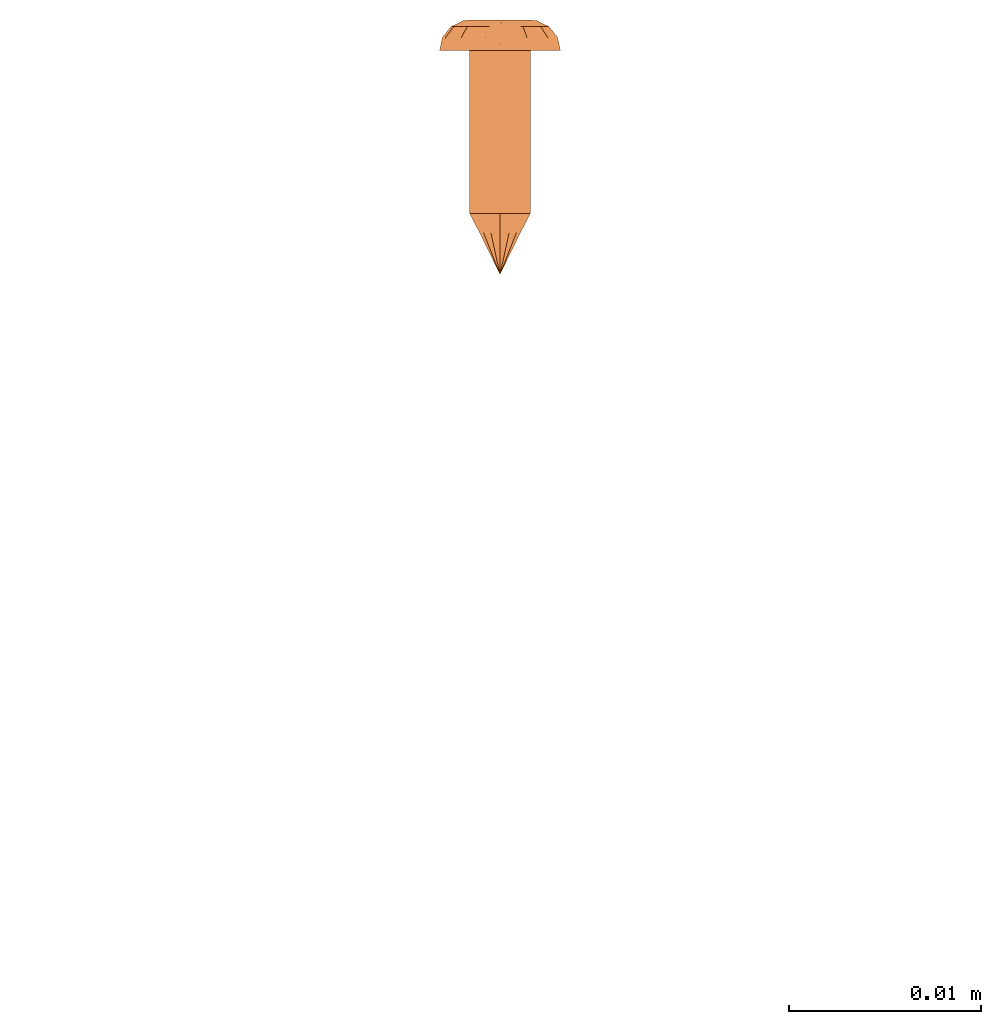
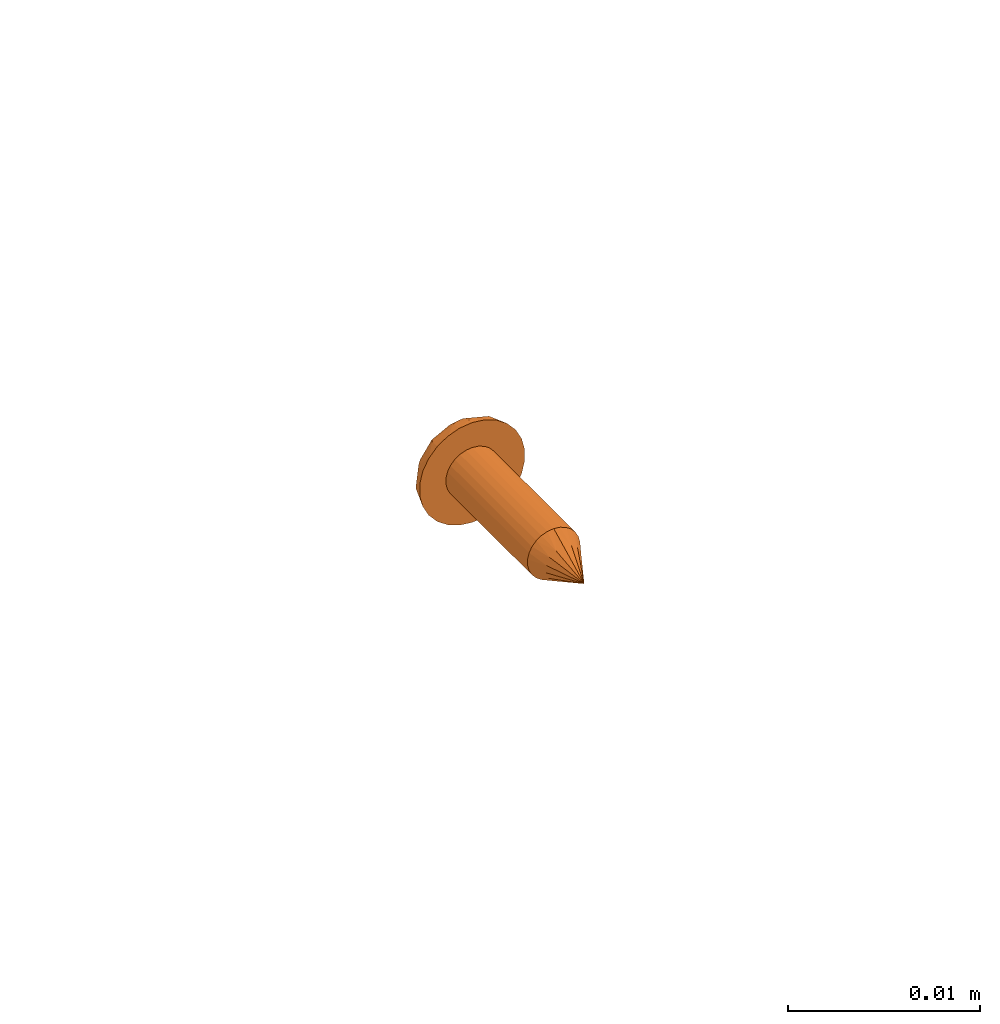
# One storey, part 41 of 44: 1 proxy.
"""IFC4 building model written with IfcOpenShell, lengths in feet."""

from ifc_helpers import new_model, entity, si_unit, converted_unit, derived_unit, direction, frame, origin, place, context, subcontext, project, spatial, source, transform, mapped, material, type_object, type_shapes, element, save


model = new_model("IFC4")

# Units and contexts
model_context = context("Model", 3, precision=0.0001, world=origin(), true_north=direction((6.12303176911189e-17, 1.0)))
body_context = subcontext(model_context, "Body", "Model", "MODEL_VIEW")
ifc_project = project(units=[converted_unit("LENGTHUNIT", "FOOT", entity("IfcRatioMeasure", 0.3048), si_unit("LENGTHUNIT", "METRE"), dimensions=[1, 0, 0, 0, 0, 0, 0]), converted_unit("AREAUNIT", "SQUARE FOOT", entity("IfcRatioMeasure", 0.09290304), si_unit("AREAUNIT", "SQUARE_METRE"), dimensions=[2, 0, 0, 0, 0, 0, 0]), converted_unit("VOLUMEUNIT", "CUBIC FOOT", entity("IfcRatioMeasure", 0.028316846592), si_unit("VOLUMEUNIT", "CUBIC_METRE"), dimensions=[3, 0, 0, 0, 0, 0, 0]), converted_unit("PLANEANGLEUNIT", "DEGREE", entity("IfcRatioMeasure", 0.0174532925199433), si_unit("PLANEANGLEUNIT", "RADIAN"), dimensions=[0, 0, 0, 0, 0, 0, 0]), si_unit("MASSUNIT", "GRAM", prefix="KILO"), derived_unit("MASSDENSITYUNIT", [(si_unit("MASSUNIT", "GRAM", prefix="KILO"), 1), (si_unit("LENGTHUNIT", "METRE"), -3)]), derived_unit("MOMENTOFINERTIAUNIT", [(si_unit("LENGTHUNIT", "METRE"), 4)]), si_unit("TIMEUNIT", "SECOND"), si_unit("FREQUENCYUNIT", "HERTZ"), si_unit("THERMODYNAMICTEMPERATUREUNIT", "DEGREE_CELSIUS"), derived_unit("THERMALTRANSMITTANCEUNIT", [(si_unit("MASSUNIT", "GRAM", prefix="KILO"), 1), (si_unit("THERMODYNAMICTEMPERATUREUNIT", "KELVIN"), -1), (si_unit("TIMEUNIT", "SECOND"), -3)]), derived_unit("VOLUMETRICFLOWRATEUNIT", [(si_unit("LENGTHUNIT", "METRE"), 3), (si_unit("TIMEUNIT", "SECOND"), -1)]), si_unit("ELECTRICCURRENTUNIT", "AMPERE"), si_unit("ELECTRICVOLTAGEUNIT", "VOLT"), si_unit("POWERUNIT", "WATT"), si_unit("FORCEUNIT", "NEWTON"), si_unit("ILLUMINANCEUNIT", "LUX"), si_unit("LUMINOUSFLUXUNIT", "LUMEN"), si_unit("LUMINOUSINTENSITYUNIT", "CANDELA"), derived_unit("USERDEFINED", [(si_unit("MASSUNIT", "GRAM", prefix="KILO"), -1), (si_unit("LENGTHUNIT", "METRE"), -2), (si_unit("TIMEUNIT", "SECOND"), 3), (si_unit("LUMINOUSFLUXUNIT", "LUMEN"), 1)]), derived_unit("LINEARVELOCITYUNIT", [(si_unit("LENGTHUNIT", "METRE"), 1), (si_unit("TIMEUNIT", "SECOND"), -1)]), si_unit("PRESSUREUNIT", "PASCAL"), derived_unit("USERDEFINED", [(si_unit("LENGTHUNIT", "METRE"), -2), (si_unit("MASSUNIT", "GRAM", prefix="KILO"), 1), (si_unit("TIMEUNIT", "SECOND"), -2)]), derived_unit("LINEARFORCEUNIT", [(si_unit("MASSUNIT", "GRAM", prefix="KILO"), 1), (si_unit("LENGTHUNIT", "METRE"), 1), (si_unit("TIMEUNIT", "SECOND"), -2), (si_unit("LENGTHUNIT", "METRE"), -1)]), derived_unit("PLANARFORCEUNIT", [(si_unit("MASSUNIT", "GRAM", prefix="KILO"), 1), (si_unit("LENGTHUNIT", "METRE"), 1), (si_unit("TIMEUNIT", "SECOND"), -2), (si_unit("LENGTHUNIT", "METRE"), -2)])], contexts=[model_context])

# Site, building, storey
site_placement = place(None, origin())
site = spatial("IfcSite", under=ifc_project, at=site_placement, CompositionType="ELEMENT")
building_placement = place(site_placement, origin())
building = spatial("IfcBuilding", under=site, at=building_placement, CompositionType="ELEMENT")
storey_placement = place(building_placement, origin())
storey = spatial("IfcBuildingStorey", under=building, at=storey_placement, CompositionType="ELEMENT", Elevation=0.0)

# Proxy
ifc_material = material(Category="Materials")
building_element_proxy_type = type_object("IfcBuildingElementProxyType", PredefinedType="NOTDEFINED", material=ifc_material)
cartesian_point_1 = entity("IfcCartesianPoint", [0.0, -0.00520833333344342, -0.0278812538651513])
vertex_point_1 = entity("IfcVertexPoint", cartesian_point_1)
cartesian_point_2 = entity("IfcCartesianPoint", [0.0, 0.00520833333334731, -0.0278812538651514])
vertex_point_2 = entity("IfcVertexPoint", cartesian_point_2)
cartesian_point_3 = entity("IfcCartesianPoint", [0.0, 0.0, -0.0278812538651514])
ifc_direction_1 = entity("IfcDirection", [0.0, 0.0, 1.0])
ifc_direction_2 = entity("IfcDirection", [0.0, 1.0, 0.0])
edge_curve_1 = entity("IfcEdgeCurve", vertex_point_1, vertex_point_2, entity("IfcTrimmedCurve", entity("IfcCircle", entity("IfcAxis2Placement3D", cartesian_point_3, ifc_direction_1, ifc_direction_2), 0.00520833333339537), [cartesian_point_1], [cartesian_point_2], True, "CARTESIAN"), True)
vertex_point_3 = entity("IfcVertexPoint", cartesian_point_3)
ifc_direction_3 = entity("IfcDirection", [0.0, -1.0, 0.0])
edge_curve_2 = entity("IfcEdgeCurve", vertex_point_2, vertex_point_3, entity("IfcTrimmedCurve", entity("IfcLine", cartesian_point_2, entity("IfcVector", ifc_direction_3, 1.0)), [cartesian_point_2], [cartesian_point_3], True, "CARTESIAN"), True)
edge_curve_3 = entity("IfcEdgeCurve", vertex_point_3, vertex_point_1, entity("IfcTrimmedCurve", entity("IfcLine", cartesian_point_3, entity("IfcVector", ifc_direction_3, 1.0)), [cartesian_point_3], [cartesian_point_1], True, "CARTESIAN"), True)
edge_curve_4 = entity("IfcEdgeCurve", vertex_point_2, vertex_point_1, entity("IfcTrimmedCurve", entity("IfcCircle", entity("IfcAxis2Placement3D", cartesian_point_3, ifc_direction_1, ifc_direction_2), 0.00520833333339537), [cartesian_point_2], [cartesian_point_1], True, "CARTESIAN"), True)
cartesian_point_4 = entity("IfcCartesianPoint", [0.0, 0.0, -0.0382979205315861])
vertex_point_4 = entity("IfcVertexPoint", cartesian_point_4)
edge_curve_5 = entity("IfcEdgeCurve", vertex_point_4, vertex_point_2, entity("IfcTrimmedCurve", entity("IfcLine", cartesian_point_4, entity("IfcVector", entity("IfcDirection", [0.0, 0.447213595512766, 0.894427190993512]), 1.0)), [cartesian_point_4], [cartesian_point_2], True, "CARTESIAN"), True)
edge_curve_6 = entity("IfcEdgeCurve", vertex_point_1, vertex_point_4, entity("IfcTrimmedCurve", entity("IfcLine", cartesian_point_1, entity("IfcVector", entity("IfcDirection", [0.0, 0.447213595512751, -0.894427190993519]), 1.0)), [cartesian_point_1], [cartesian_point_4], True, "CARTESIAN"), True)
cartesian_point_5 = entity("IfcCartesianPoint", [-0.0052083333333639, 0.0, -0.0278812538651513])
cartesian_point_6 = entity("IfcCartesianPoint", [0.0, 0.0, -0.0327501051227764])
ifc_direction_4 = entity("IfcDirection", [0.0, 0.0, -1.0])
cartesian_point_7 = entity("IfcCartesianPoint", [0.0, 0.0104166666665518, 0.0])
vertex_point_5 = entity("IfcVertexPoint", cartesian_point_7)
cartesian_point_8 = entity("IfcCartesianPoint", [0.0, -0.0104166666669052, 0.0])
vertex_point_6 = entity("IfcVertexPoint", cartesian_point_8)
cartesian_point_9 = entity("IfcCartesianPoint", [0.0, 0.0, 0.0])
ifc_direction_5 = entity("IfcDirection", [0.0, 0.0, -1.0])
ifc_direction_6 = entity("IfcDirection", [0.0, -1.0, 0.0])
edge_curve_7 = entity("IfcEdgeCurve", vertex_point_5, vertex_point_6, entity("IfcTrimmedCurve", entity("IfcCircle", entity("IfcAxis2Placement3D", cartesian_point_9, ifc_direction_5, ifc_direction_6), 0.0104166666667285), [cartesian_point_7], [cartesian_point_8], True, "CARTESIAN"), True)
vertex_point_7 = entity("IfcVertexPoint", cartesian_point_9)
ifc_direction_7 = entity("IfcDirection", [0.0, 1.0, 0.0])
edge_curve_8 = entity("IfcEdgeCurve", vertex_point_6, vertex_point_7, entity("IfcTrimmedCurve", entity("IfcLine", cartesian_point_8, entity("IfcVector", ifc_direction_7, 1.0)), [cartesian_point_8], [cartesian_point_9], True, "CARTESIAN"), True)
edge_curve_9 = entity("IfcEdgeCurve", vertex_point_7, vertex_point_5, entity("IfcTrimmedCurve", entity("IfcLine", cartesian_point_9, entity("IfcVector", ifc_direction_7, 1.0)), [cartesian_point_9], [cartesian_point_7], True, "CARTESIAN"), True)
edge_curve_10 = entity("IfcEdgeCurve", vertex_point_6, vertex_point_5, entity("IfcTrimmedCurve", entity("IfcCircle", entity("IfcAxis2Placement3D", cartesian_point_9, ifc_direction_5, ifc_direction_6), 0.0104166666667285), [cartesian_point_8], [cartesian_point_7], True, "CARTESIAN"), True)
cartesian_point_10 = entity("IfcCartesianPoint", [0.0, 0.0, 0.00520833333310164])
vertex_point_8 = entity("IfcVertexPoint", cartesian_point_10)
cartesian_point_11 = entity("IfcCartesianPoint", [0.0, -0.00520833333357187, 0.00520833333310168])
vertex_point_9 = entity("IfcVertexPoint", cartesian_point_11)
edge_curve_11 = entity("IfcEdgeCurve", vertex_point_8, vertex_point_9, entity("IfcTrimmedCurve", entity("IfcLine", cartesian_point_10, entity("IfcVector", ifc_direction_6, 1.0)), [cartesian_point_10], [cartesian_point_11], True, "CARTESIAN"), True)
cartesian_point_12 = entity("IfcCartesianPoint", [0.0, 0.00520833333321853, 0.00520833333310159])
vertex_point_10 = entity("IfcVertexPoint", cartesian_point_12)
ifc_direction_8 = entity("IfcDirection", [0.0, 0.0, 1.0])
edge_curve_12 = entity("IfcEdgeCurve", vertex_point_9, vertex_point_10, entity("IfcTrimmedCurve", entity("IfcCircle", entity("IfcAxis2Placement3D", cartesian_point_10, ifc_direction_8, ifc_direction_6), 0.00520833333339523), [cartesian_point_11], [cartesian_point_12], True, "CARTESIAN"), True)
edge_curve_13 = entity("IfcEdgeCurve", vertex_point_10, vertex_point_8, entity("IfcTrimmedCurve", entity("IfcLine", cartesian_point_12, entity("IfcVector", ifc_direction_6, 1.0)), [cartesian_point_12], [cartesian_point_10], True, "CARTESIAN"), True)
edge_curve_14 = entity("IfcEdgeCurve", vertex_point_10, vertex_point_9, entity("IfcTrimmedCurve", entity("IfcCircle", entity("IfcAxis2Placement3D", cartesian_point_10, ifc_direction_8, ifc_direction_6), 0.00520833333339523), [cartesian_point_12], [cartesian_point_11], True, "CARTESIAN"), True)
ifc_direction_9 = entity("IfcDirection", [1.0, 0.0, 0.0])
edge_curve_15 = entity("IfcEdgeCurve", vertex_point_9, vertex_point_6, entity("IfcTrimmedCurve", entity("IfcCircle", entity("IfcAxis2Placement3D", entity("IfcCartesianPoint", [0.0, -0.00520833333357193, 0.0]), ifc_direction_9, ifc_direction_6), 0.00520833333333331), [cartesian_point_11], [cartesian_point_8], True, "CARTESIAN"), True)
edge_curve_16 = entity("IfcEdgeCurve", vertex_point_5, vertex_point_10, entity("IfcTrimmedCurve", entity("IfcCircle", entity("IfcAxis2Placement3D", entity("IfcCartesianPoint", [0.0, 0.0052083333332185, 0.0]), ifc_direction_9, ifc_direction_7), 0.00520833333333331), [cartesian_point_7], [cartesian_point_12], True, "CARTESIAN"), True)
cartesian_point_13 = entity("IfcCartesianPoint", [0.00520833333332085, 0.0, 0.0])
cartesian_point_14 = entity("IfcCartesianPoint", [0.0104166666666542, 0.0, 0.0])
cartesian_point_15 = entity("IfcCartesianPoint", [0.0052083333333208, 0.0, 0.00520833333310163])
cartesian_point_16 = entity("IfcCartesianPoint", [0.0, -0.00520833333348769, 0.0])
vertex_point_11 = entity("IfcVertexPoint", cartesian_point_16)
cartesian_point_17 = entity("IfcCartesianPoint", [0.0, 0.00520833333317898, 0.0])
vertex_point_12 = entity("IfcVertexPoint", cartesian_point_17)
cartesian_point_18 = entity("IfcCartesianPoint", [0.0, 0.0, 0.0])
ifc_direction_10 = entity("IfcDirection", [0.0, 0.0, 1.0])
ifc_direction_11 = entity("IfcDirection", [0.0, 1.0, 0.0])
edge_curve_17 = entity("IfcEdgeCurve", vertex_point_11, vertex_point_12, entity("IfcTrimmedCurve", entity("IfcCircle", entity("IfcAxis2Placement3D", cartesian_point_18, ifc_direction_10, ifc_direction_11), 0.00520833333333333), [cartesian_point_16], [cartesian_point_17], True, "CARTESIAN"), True)
edge_curve_18 = entity("IfcEdgeCurve", vertex_point_12, vertex_point_11, entity("IfcTrimmedCurve", entity("IfcCircle", entity("IfcAxis2Placement3D", cartesian_point_18, ifc_direction_10, ifc_direction_11), 0.00520833333333333), [cartesian_point_17], [cartesian_point_16], True, "CARTESIAN"), True)
cartesian_point_19 = entity("IfcCartesianPoint", [0.0, -0.00520833333348793, -0.0278812538652589])
vertex_point_13 = entity("IfcVertexPoint", cartesian_point_19)
cartesian_point_20 = entity("IfcCartesianPoint", [0.0, 0.00520833333317874, -0.027881253865259])
vertex_point_14 = entity("IfcVertexPoint", cartesian_point_20)
cartesian_point_21 = entity("IfcCartesianPoint", [0.0, 0.0, -0.027881253865259])
ifc_direction_12 = entity("IfcDirection", [0.0, 0.0, -1.0])
edge_curve_19 = entity("IfcEdgeCurve", vertex_point_13, vertex_point_14, entity("IfcTrimmedCurve", entity("IfcCircle", entity("IfcAxis2Placement3D", cartesian_point_21, ifc_direction_12, ifc_direction_11), 0.00520833333333333), [cartesian_point_19], [cartesian_point_20], True, "CARTESIAN"), True)
edge_curve_20 = entity("IfcEdgeCurve", vertex_point_14, vertex_point_13, entity("IfcTrimmedCurve", entity("IfcCircle", entity("IfcAxis2Placement3D", cartesian_point_21, ifc_direction_12, ifc_direction_11), 0.00520833333333333), [cartesian_point_20], [cartesian_point_19], True, "CARTESIAN"), True)
edge_curve_21 = entity("IfcEdgeCurve", vertex_point_11, vertex_point_13, entity("IfcTrimmedCurve", entity("IfcLine", cartesian_point_16, entity("IfcVector", ifc_direction_12, 1.0)), [cartesian_point_16], [cartesian_point_19], True, "CARTESIAN"), True)
edge_curve_22 = entity("IfcEdgeCurve", vertex_point_14, vertex_point_12, entity("IfcTrimmedCurve", entity("IfcLine", cartesian_point_17, entity("IfcVector", ifc_direction_10, 1.0)), [cartesian_point_20], [cartesian_point_17], True, "CARTESIAN"), True)
shared_shape = source(origin(), body_context, "Body", "AdvancedBrep", [
    entity("IfcAdvancedBrep", entity("IfcClosedShell", [entity("IfcAdvancedFace", [entity("IfcFaceOuterBound", entity("IfcEdgeLoop", [entity("IfcOrientedEdge", None, None, edge_curve_1, True), entity("IfcOrientedEdge", None, None, edge_curve_2, True), entity("IfcOrientedEdge", None, None, edge_curve_3, True)]), True)], entity("IfcPlane", entity("IfcAxis2Placement3D", cartesian_point_3, ifc_direction_1, ifc_direction_2)), True), entity("IfcAdvancedFace", [entity("IfcFaceOuterBound", entity("IfcEdgeLoop", [entity("IfcOrientedEdge", None, None, edge_curve_4, True), entity("IfcOrientedEdge", None, None, edge_curve_3, False), entity("IfcOrientedEdge", None, None, edge_curve_2, False)]), True)], entity("IfcPlane", entity("IfcAxis2Placement3D", cartesian_point_3, ifc_direction_1, ifc_direction_2)), True), entity("IfcAdvancedFace", [entity("IfcFaceOuterBound", entity("IfcEdgeLoop", [entity("IfcOrientedEdge", None, None, edge_curve_5, True), entity("IfcOrientedEdge", None, None, edge_curve_1, False), entity("IfcOrientedEdge", None, None, edge_curve_6, True)]), True)], entity("IfcSurfaceOfRevolution", entity("IfcArbitraryOpenProfileDef", "CURVE", None, entity("IfcTrimmedCurve", entity("IfcLine", cartesian_point_4, entity("IfcVector", entity("IfcDirection", [0.447213595512749, 0.0, -0.894427190993521]), 1.0)), [cartesian_point_5], [cartesian_point_4], True, "CARTESIAN")), None, entity("IfcAxis1Placement", cartesian_point_6, ifc_direction_4)), True), entity("IfcAdvancedFace", [entity("IfcFaceOuterBound", entity("IfcEdgeLoop", [entity("IfcOrientedEdge", None, None, edge_curve_6, False), entity("IfcOrientedEdge", None, None, edge_curve_4, False), entity("IfcOrientedEdge", None, None, edge_curve_5, False)]), True)], entity("IfcSurfaceOfRevolution", entity("IfcArbitraryOpenProfileDef", "CURVE", None, entity("IfcTrimmedCurve", entity("IfcLine", cartesian_point_4, entity("IfcVector", entity("IfcDirection", [0.447213595512749, 0.0, -0.894427190993521]), 1.0)), [cartesian_point_5], [cartesian_point_4], True, "CARTESIAN")), None, entity("IfcAxis1Placement", cartesian_point_6, ifc_direction_4)), True)])),
    entity("IfcAdvancedBrep", entity("IfcClosedShell", [entity("IfcAdvancedFace", [entity("IfcFaceOuterBound", entity("IfcEdgeLoop", [entity("IfcOrientedEdge", None, None, edge_curve_7, True), entity("IfcOrientedEdge", None, None, edge_curve_8, True), entity("IfcOrientedEdge", None, None, edge_curve_9, True)]), True)], entity("IfcPlane", entity("IfcAxis2Placement3D", cartesian_point_9, ifc_direction_5, ifc_direction_6)), True), entity("IfcAdvancedFace", [entity("IfcFaceOuterBound", entity("IfcEdgeLoop", [entity("IfcOrientedEdge", None, None, edge_curve_10, True), entity("IfcOrientedEdge", None, None, edge_curve_9, False), entity("IfcOrientedEdge", None, None, edge_curve_8, False)]), True)], entity("IfcPlane", entity("IfcAxis2Placement3D", cartesian_point_9, ifc_direction_5, ifc_direction_6)), True), entity("IfcAdvancedFace", [entity("IfcFaceOuterBound", entity("IfcEdgeLoop", [entity("IfcOrientedEdge", None, None, edge_curve_11, True), entity("IfcOrientedEdge", None, None, edge_curve_12, True), entity("IfcOrientedEdge", None, None, edge_curve_13, True)]), True)], entity("IfcPlane", entity("IfcAxis2Placement3D", cartesian_point_10, ifc_direction_8, ifc_direction_6)), True), entity("IfcAdvancedFace", [entity("IfcFaceOuterBound", entity("IfcEdgeLoop", [entity("IfcOrientedEdge", None, None, edge_curve_13, False), entity("IfcOrientedEdge", None, None, edge_curve_14, True), entity("IfcOrientedEdge", None, None, edge_curve_11, False)]), True)], entity("IfcPlane", entity("IfcAxis2Placement3D", cartesian_point_10, ifc_direction_8, ifc_direction_6)), True), entity("IfcAdvancedFace", [entity("IfcFaceOuterBound", entity("IfcEdgeLoop", [entity("IfcOrientedEdge", None, None, edge_curve_12, False), entity("IfcOrientedEdge", None, None, edge_curve_15, True), entity("IfcOrientedEdge", None, None, edge_curve_7, False), entity("IfcOrientedEdge", None, None, edge_curve_16, True)]), True)], entity("IfcSurfaceOfRevolution", entity("IfcArbitraryOpenProfileDef", "CURVE", None, entity("IfcTrimmedCurve", entity("IfcCircle", entity("IfcAxis2Placement3D", cartesian_point_13, ifc_direction_6, ifc_direction_9), 0.00520833333333331), [cartesian_point_14], [cartesian_point_15], True, "CARTESIAN")), None, entity("IfcAxis1Placement", cartesian_point_10, ifc_direction_8)), True), entity("IfcAdvancedFace", [entity("IfcFaceOuterBound", entity("IfcEdgeLoop", [entity("IfcOrientedEdge", None, None, edge_curve_14, False), entity("IfcOrientedEdge", None, None, edge_curve_16, False), entity("IfcOrientedEdge", None, None, edge_curve_10, False), entity("IfcOrientedEdge", None, None, edge_curve_15, False)]), True)], entity("IfcSurfaceOfRevolution", entity("IfcArbitraryOpenProfileDef", "CURVE", None, entity("IfcTrimmedCurve", entity("IfcCircle", entity("IfcAxis2Placement3D", cartesian_point_13, ifc_direction_6, ifc_direction_9), 0.00520833333333331), [cartesian_point_14], [cartesian_point_15], True, "CARTESIAN")), None, entity("IfcAxis1Placement", cartesian_point_10, ifc_direction_8)), True)])),
    entity("IfcAdvancedBrep", entity("IfcClosedShell", [entity("IfcAdvancedFace", [entity("IfcFaceOuterBound", entity("IfcEdgeLoop", [entity("IfcOrientedEdge", None, None, edge_curve_17, True), entity("IfcOrientedEdge", None, None, edge_curve_18, True)]), True)], entity("IfcPlane", entity("IfcAxis2Placement3D", cartesian_point_17, ifc_direction_10, entity("IfcDirection", [-1.0, 0.0, 0.0]))), True), entity("IfcAdvancedFace", [entity("IfcFaceOuterBound", entity("IfcEdgeLoop", [entity("IfcOrientedEdge", None, None, edge_curve_19, True), entity("IfcOrientedEdge", None, None, edge_curve_20, True)]), True)], entity("IfcPlane", entity("IfcAxis2Placement3D", cartesian_point_20, ifc_direction_12, entity("IfcDirection", [1.0, 0.0, 0.0]))), True), entity("IfcAdvancedFace", [entity("IfcFaceOuterBound", entity("IfcEdgeLoop", [entity("IfcOrientedEdge", None, None, edge_curve_17, False), entity("IfcOrientedEdge", None, None, edge_curve_21, True), entity("IfcOrientedEdge", None, None, edge_curve_20, False), entity("IfcOrientedEdge", None, None, edge_curve_22, True)]), True)], entity("IfcCylindricalSurface", entity("IfcAxis2Placement3D", cartesian_point_21, ifc_direction_10, ifc_direction_11), 0.00520833333333333), True), entity("IfcAdvancedFace", [entity("IfcFaceOuterBound", entity("IfcEdgeLoop", [entity("IfcOrientedEdge", None, None, edge_curve_18, False), entity("IfcOrientedEdge", None, None, edge_curve_22, False), entity("IfcOrientedEdge", None, None, edge_curve_19, False), entity("IfcOrientedEdge", None, None, edge_curve_21, False)]), True)], entity("IfcCylindricalSurface", entity("IfcAxis2Placement3D", cartesian_point_21, ifc_direction_10, ifc_direction_11), 0.00520833333333333), True)])),
])
type_shapes(building_element_proxy_type, [shared_shape])
proxy_placement = place(storey_placement, frame((1490.88274831605, 12.1740389879227, 7.92960166580535), z_axis=(0.0, 1.0, 0.0), x_axis=(-1.0, 0.0, 0.0)))
element("IfcBuildingElementProxy", 1, at=proxy_placement, inside=storey, type_object=building_element_proxy_type, material=ifc_material, PredefinedType="NOTDEFINED", context=body_context, shape_type="MappedRepresentation", body=[
    mapped(shared_shape, transform((0.0, 0.0, 0.0), scale=1.0)),
])

save(model, "model.ifc")
